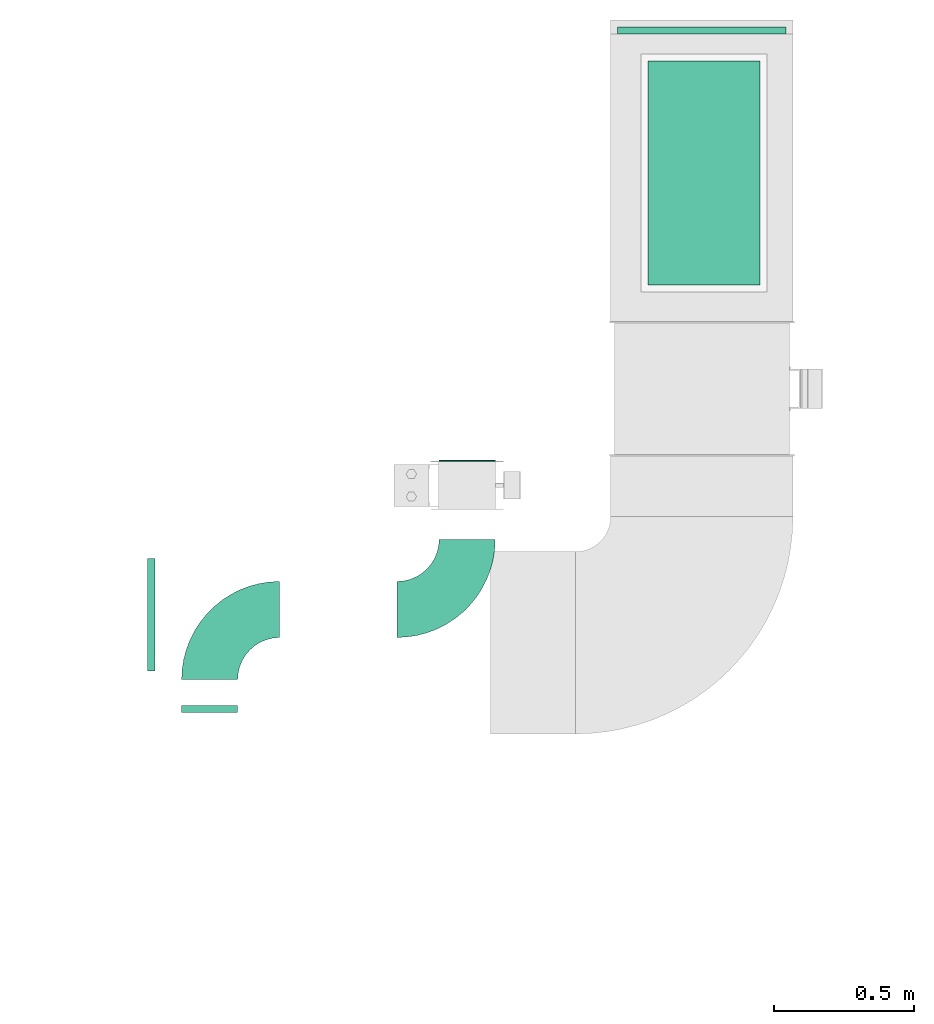
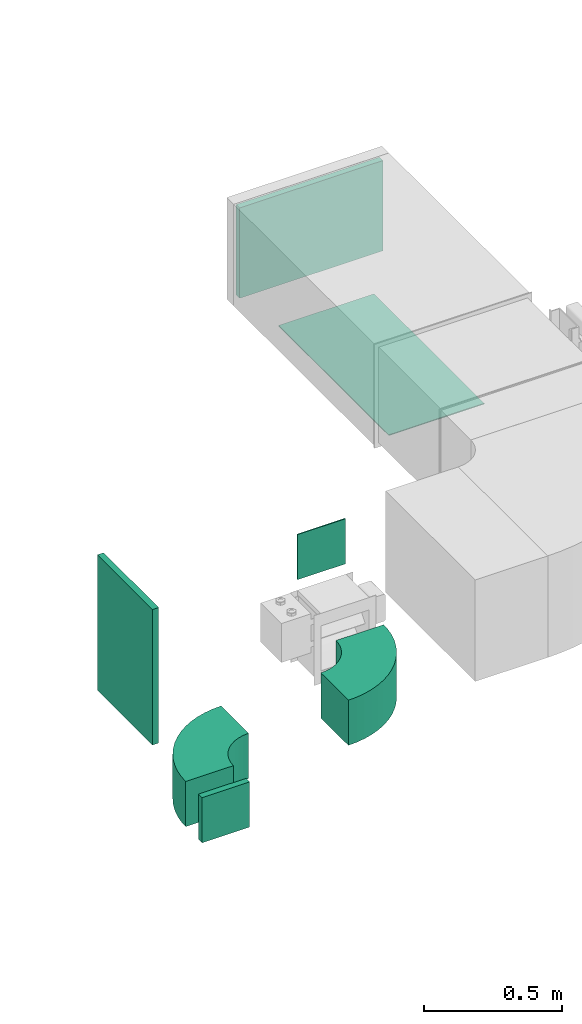
# One storey, part 3 of 8: 5 flow fittings, 2 flow terminals.
"""IFC2X3 building model written with IfcOpenShell, lengths in millimetres."""

from ifc_helpers import new_model, entity, si_unit, converted_unit, derived_unit, direction, frame, frame_2d, origin, origin_2d_with_axis, place, context, subcontext, project, spatial, polyline, circle_curve, parameter, trimmed, segment, composite_curve, rectangle, outline, extrude, source, transform, mapped, material, type_object, type_shapes, element, save


model = new_model("IFC2X3")

# Units and contexts
model_context = context("Model", 3, precision=0.01, world=origin(), true_north=direction((6.12303176911189e-17, 1.0)))
body_context = subcontext(model_context, "Body", "Model", "MODEL_VIEW")
ifc_project = project(units=[si_unit("LENGTHUNIT", "METRE", prefix="MILLI"), si_unit("AREAUNIT", "SQUARE_METRE"), si_unit("VOLUMEUNIT", "CUBIC_METRE"), converted_unit("PLANEANGLEUNIT", "DEGREE", entity("IfcRatioMeasure", 0.0174532925199433), si_unit("PLANEANGLEUNIT", "RADIAN"), dimensions=[0, 0, 0, 0, 0, 0, 0]), si_unit("MASSUNIT", "GRAM", prefix="KILO"), derived_unit("MASSDENSITYUNIT", [(si_unit("MASSUNIT", "GRAM", prefix="KILO"), 1), (si_unit("LENGTHUNIT", "METRE"), -3)]), derived_unit("MOMENTOFINERTIAUNIT", [(si_unit("LENGTHUNIT", "METRE"), 4)]), si_unit("TIMEUNIT", "SECOND"), si_unit("FREQUENCYUNIT", "HERTZ"), si_unit("THERMODYNAMICTEMPERATUREUNIT", "DEGREE_CELSIUS"), derived_unit("THERMALTRANSMITTANCEUNIT", [(si_unit("MASSUNIT", "GRAM", prefix="KILO"), 1), (si_unit("THERMODYNAMICTEMPERATUREUNIT", "KELVIN"), -1), (si_unit("TIMEUNIT", "SECOND"), -3)]), derived_unit("VOLUMETRICFLOWRATEUNIT", [(si_unit("LENGTHUNIT", "METRE"), 3), (si_unit("TIMEUNIT", "SECOND"), -1)]), derived_unit("MASSFLOWRATEUNIT", [(si_unit("MASSUNIT", "GRAM", prefix="KILO"), 1), (si_unit("TIMEUNIT", "SECOND"), -1)]), derived_unit("ROTATIONALFREQUENCYUNIT", [(si_unit("TIMEUNIT", "SECOND"), -1)]), si_unit("ELECTRICCURRENTUNIT", "AMPERE"), si_unit("ELECTRICVOLTAGEUNIT", "VOLT"), si_unit("POWERUNIT", "WATT"), si_unit("FORCEUNIT", "NEWTON", prefix="KILO"), si_unit("ILLUMINANCEUNIT", "LUX"), si_unit("LUMINOUSFLUXUNIT", "LUMEN"), si_unit("LUMINOUSINTENSITYUNIT", "CANDELA"), derived_unit("USERDEFINED", [(si_unit("MASSUNIT", "GRAM", prefix="KILO"), -1), (si_unit("LENGTHUNIT", "METRE"), -2), (si_unit("TIMEUNIT", "SECOND"), 3), (si_unit("LUMINOUSFLUXUNIT", "LUMEN"), 1)]), derived_unit("LINEARVELOCITYUNIT", [(si_unit("LENGTHUNIT", "METRE"), 1), (si_unit("TIMEUNIT", "SECOND"), -1)]), si_unit("PRESSUREUNIT", "PASCAL"), derived_unit("USERDEFINED", [(si_unit("LENGTHUNIT", "METRE"), -2), (si_unit("MASSUNIT", "GRAM", prefix="KILO"), 1), (si_unit("TIMEUNIT", "SECOND"), -2)]), derived_unit("LINEARFORCEUNIT", [(si_unit("MASSUNIT", "GRAM", prefix="KILO"), 1), (si_unit("LENGTHUNIT", "METRE"), 1), (si_unit("TIMEUNIT", "SECOND"), -2), (si_unit("LENGTHUNIT", "METRE"), -1)]), derived_unit("PLANARFORCEUNIT", [(si_unit("MASSUNIT", "GRAM", prefix="KILO"), 1), (si_unit("LENGTHUNIT", "METRE"), 1), (si_unit("TIMEUNIT", "SECOND"), -2), (si_unit("LENGTHUNIT", "METRE"), -2)])], contexts=[model_context])

# Site, building, storey
site_placement = place(None, origin())
site = spatial("IfcSite", under=ifc_project, at=site_placement, CompositionType="ELEMENT")
building_placement = place(site_placement, origin())
building = spatial("IfcBuilding", under=site, at=building_placement, CompositionType="ELEMENT")
storey_placement = place(building_placement, frame((0.0, 0.0, 4200.0)))
storey = spatial("IfcBuildingStorey", under=building, at=storey_placement, CompositionType="ELEMENT", Elevation=4200.0)

# Flow fittings
ifc_material_1 = material()
duct_fitting_type_1 = type_object("IfcDuctFittingType", PredefinedType="NOTDEFINED", material=ifc_material_1)
shared_shape_1 = source(origin(), body_context, "Body", "SweptSolid", [
    extrude(rectangle(XDim=26.0960000000009, YDim=600.0, at=origin_2d_with_axis()), frame((6.95, 0.0, -200.0)), (0.0, 0.0, 1.0), 400.0),
])
type_shapes(duct_fitting_type_1, [shared_shape_1])
flow_fitting_1_placement = place(storey_placement, frame((10029.73, 14794.08, 3285.13), z_axis=(0.0, -1.0, 0.0), x_axis=(1.0, 0.0, 0.0)))
element("IfcFlowFitting", 1, at=flow_fitting_1_placement, inside=storey, type_object=duct_fitting_type_1, material=ifc_material_1, context=body_context, shape_type="MappedRepresentation", body=[
    mapped(shared_shape_1, transform((0.0, 0.0, 0.0), scale=1.0)),
])
duct_fitting_type_2 = type_object("IfcDuctFittingType", PredefinedType="NOTDEFINED", material=ifc_material_1)
shared_shape_2 = source(origin(), body_context, "Body", "SweptSolid", [
    extrude(rectangle(XDim=24.9999999999999, YDim=600.0, at=origin_2d_with_axis()), frame((12.5, 0.0, -200.0)), (0.0, 0.0, 1.0), 400.0),
])
type_shapes(duct_fitting_type_2, [shared_shape_2])
flow_fitting_2_placement = place(storey_placement, frame((12000.22, 16865.38, 3200.0), z_axis=(0.0, 0.0, 1.0), x_axis=(0.0, 1.0, 0.0)))
element("IfcFlowFitting", 2, at=flow_fitting_2_placement, inside=storey, type_object=duct_fitting_type_2, material=ifc_material_1, context=body_context, shape_type="MappedRepresentation", body=[
    mapped(shared_shape_2, transform((0.0, 0.0, 0.0), scale=1.0)),
])

# Flow terminals
ifc_material_2 = material()
air_terminal_type_1 = type_object("IfcAirTerminalType", PredefinedType="NOTDEFINED", material=ifc_material_2)
shared_shape_3 = source(origin(), body_context, "Body", "SweptSolid", [
    extrude(rectangle(XDim=4.0, YDim=799.999999999999, at=origin_2d_with_axis()), frame((0.0, -2.0, -200.0), z_axis=(0.0, 0.0, 1.0), x_axis=(0.0, 1.0, 0.0)), (0.0, 0.0, 1.0), 400.000000000005),
])
type_shapes(air_terminal_type_1, [shared_shape_3])
flow_terminal_1_placement = place(storey_placement, frame((12008.22, 16369.97, 2900.0), z_axis=(-1.0, 0.0, 0.0), x_axis=(0.0, -1.0, 0.0)))
element("IfcFlowTerminal", 3, at=flow_terminal_1_placement, inside=storey, type_object=air_terminal_type_1, material=ifc_material_2, context=body_context, shape_type="MappedRepresentation", body=[
    mapped(shared_shape_3, transform((0.0, 0.0, 0.0), scale=1.0)),
])
air_terminal_type_2 = type_object("IfcAirTerminalType", PredefinedType="NOTDEFINED", material=ifc_material_2)
shared_shape_4 = source(origin(), body_context, "Body", "SweptSolid", [
    extrude(rectangle(XDim=4.0, YDim=199.999999999999, at=origin_2d_with_axis()), frame((0.0, -2.0, -100.0), z_axis=(0.0, 0.0, 1.0), x_axis=(0.0, 1.0, 0.0)), (0.0, 0.0, 1.0), 200.000000000005),
])
type_shapes(air_terminal_type_2, [shared_shape_4])
flow_terminal_2_placement = place(storey_placement, frame((11163.25, 15341.88, 3000.0), z_axis=(0.0, 0.0, 1.0), x_axis=(-1.0, 0.0, 0.0)))
element("IfcFlowTerminal", 4, at=flow_terminal_2_placement, inside=storey, type_object=air_terminal_type_2, material=ifc_material_2, context=body_context, shape_type="MappedRepresentation", body=[
    mapped(shared_shape_4, transform((0.0, 0.0, 0.0), scale=1.0)),
])

# Flow fittings
duct_fitting_type_3 = type_object("IfcDuctFittingType", PredefinedType="NOTDEFINED", material=ifc_material_1)
shared_shape_5 = source(origin(), body_context, "Body", "SweptSolid", [
    extrude(rectangle(XDim=26.0960000000003, YDim=200.0, at=origin_2d_with_axis()), frame((6.95, 0.0, -100.0)), (0.0, 0.0, 1.0), 200.0),
])
type_shapes(duct_fitting_type_3, [shared_shape_5])
flow_fitting_3_placement = place(storey_placement, frame((10244.72, 14450.84, 2700.0), z_axis=(1.0, 0.0, 0.0), x_axis=(0.0, 1.0, 0.0)))
element("IfcFlowFitting", 5, at=flow_fitting_3_placement, inside=storey, type_object=duct_fitting_type_3, material=ifc_material_1, context=body_context, shape_type="MappedRepresentation", body=[
    mapped(shared_shape_5, transform((0.0, 0.0, 0.0), scale=1.0)),
])
duct_fitting_type_4 = type_object("IfcDuctFittingType", PredefinedType="NOTDEFINED", material=ifc_material_1)
shared_shape_6 = source(origin(), body_context, "Body", "SweptSolid", [
    extrude(outline(composite_curve([segment(polyline([(-225.0, -125.0), (-25.0, -125.0)]), True, "CONTINUOUS"), segment(trimmed(circle_curve(frame_2d((125.0, -125.0), x_axis=(0.0, 1.0)), 150.0), [parameter(0.0)], [parameter(90.0000000000001)], True, "PARAMETER"), False, "CONTINUOUS"), segment(polyline([(125.0, 25.0), (125.0, 225.0)]), True, "CONTINUOUS"), segment(trimmed(circle_curve(frame_2d((125.0, -125.0), x_axis=(0.0, 1.0)), 350.0), [parameter(0.0)], [parameter(90.0000000000001)], True, "PARAMETER"), True, "CONTINUOUS")], self_intersect=False)), frame((-125.0, 125.0, -100.0), z_axis=(0.0, 0.0, 1.0), x_axis=(-1.0, 0.0, 0.0)), (0.0, 0.0, 1.0), 200.0),
])
type_shapes(duct_fitting_type_4, [shared_shape_6])
flow_fitting_4_placement = place(storey_placement, frame((11163.25, 14813.05, 2700.0)))
element("IfcFlowFitting", 6, at=flow_fitting_4_placement, inside=storey, type_object=duct_fitting_type_4, material=ifc_material_1, context=body_context, shape_type="MappedRepresentation", body=[
    mapped(shared_shape_6, transform((0.0, 0.0, 0.0), scale=1.0)),
])
flow_fitting_5_placement = place(storey_placement, frame((10244.72, 14813.05, 2700.0), z_axis=(0.0, 0.0, 1.0), x_axis=(-1.0, 0.0, 0.0)))
element("IfcFlowFitting", 7, at=flow_fitting_5_placement, inside=storey, type_object=duct_fitting_type_4, material=ifc_material_1, context=body_context, shape_type="MappedRepresentation", body=[
    mapped(shared_shape_6, transform((0.0, 0.0, 0.0), scale=1.0)),
])

save(model, "model.ifc")
